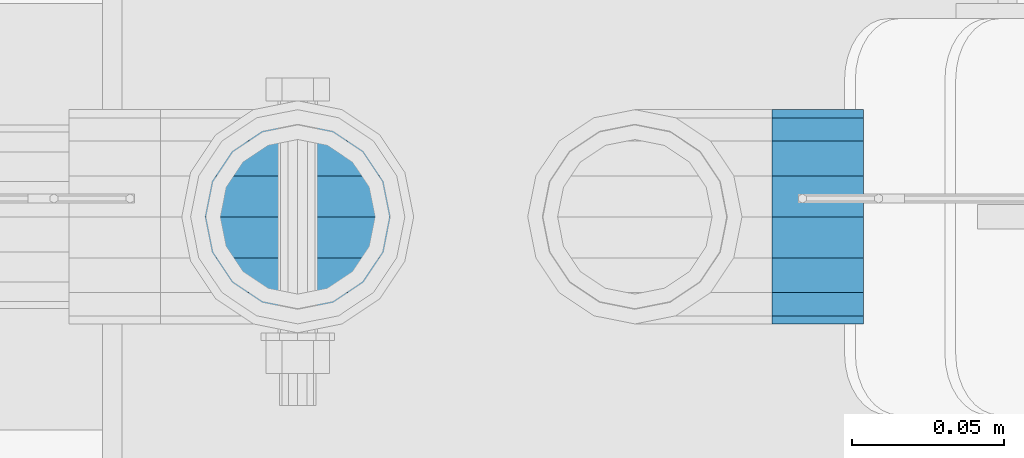
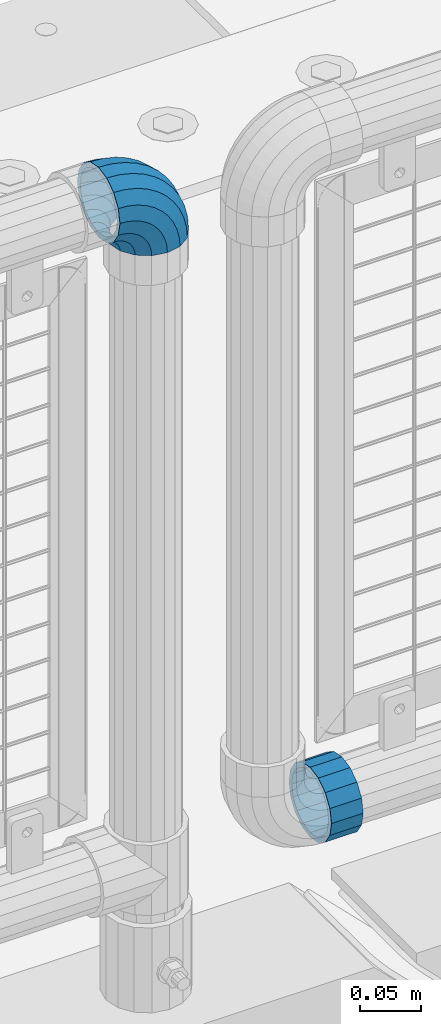
# One storey, part 182 of 270: 1 beam, 1 member.
"""IFC2X3 building model written with IfcOpenShell, lengths in millimetres."""

from ifc_helpers import new_model, si_unit, frame, origin_with_axes, place, context, subcontext, project, spatial, faceted_brep, material, type_object, element, save


model = new_model("IFC2X3")

# Units and contexts
model_context = context("Model", 3, precision=1e-05, world=origin_with_axes())
body_context = subcontext(model_context, "Body", "Model", "MODEL_VIEW")
ifc_project = project(units=[si_unit("LENGTHUNIT", "METRE", prefix="MILLI"), si_unit("AREAUNIT", "SQUARE_METRE"), si_unit("VOLUMEUNIT", "CUBIC_METRE"), si_unit("MASSUNIT", "GRAM", prefix="KILO"), si_unit("TIMEUNIT", "SECOND"), si_unit("PLANEANGLEUNIT", "RADIAN"), si_unit("SOLIDANGLEUNIT", "STERADIAN"), si_unit("THERMODYNAMICTEMPERATUREUNIT", "DEGREE_CELSIUS"), si_unit("LUMINOUSINTENSITYUNIT", "LUMEN")], contexts=[model_context])

# Site, building, storey
site_placement = place(None, origin_with_axes())
site = spatial("IfcSite", under=ifc_project, at=site_placement, CompositionType="ELEMENT")
building_placement = place(site_placement, origin_with_axes())
building = spatial("IfcBuilding", under=site, at=building_placement, Name="Standard", CompositionType="ELEMENT")
storey_placement = place(building_placement, origin_with_axes())
storey = spatial("IfcBuildingStorey", under=building, at=storey_placement, Name="Undefined", CompositionType="ELEMENT", Elevation=0.0)

# Beam
ifc_material = material(Name="Misc_Undefined")
beam_type = type_object("IfcBeamType", PredefinedType="NOTDEFINED")
beam_placement = place(storey_placement, frame((18739.61, -16335.5, 298.170000000001), z_axis=(0.0, 0.0, -1.0), x_axis=(1.0, 0.0, 0.0)))
element("IfcBeam", 1, at=beam_placement, inside=storey, type_object=beam_type, material=ifc_material, context=body_context, shape_type="Brep", body=[
    faceted_brep([(0.0, -30.3500000000004, 0.0), (0.0, -28.0397438117179, 11.614442172282), (30.0, -28.0397438117179, 11.6144421722805), (30.0, -30.3500000000004, 0.0), (0.0, -21.4606908090118, 21.46069080901), (30.0, -21.4606908090118, 21.4606908090117), (0.0, -11.6144421722802, 28.0397438117179), (30.0, -11.6144421722802, 28.0397438117176), (0.0, 0.0, 30.3499999999985), (30.0, 0.0, 30.35), (0.0, 11.6144421722802, 28.0397438117179), (30.0, 11.6144421722802, 28.0397438117176), (0.0, 21.4606908090118, 21.46069080901), (30.0, 21.4606908090118, 21.4606908090117), (0.0, 28.0397438117179, 11.614442172282), (30.0, 28.0397438117179, 11.6144421722805), (0.0, 30.3500000000004, 0.0), (30.0, 30.3500000000004, 0.0), (0.0, 28.0397438117179, -11.614442172282), (30.0, 28.0397438117179, -11.6144421722805), (0.0, 21.4606908090118, -21.46069080901), (30.0, 21.4606908090118, -21.4606908090117), (0.0, 11.6144421722802, -28.0397438117179), (30.0, 11.6144421722802, -28.0397438117176), (0.0, 0.0, -30.3499999999985), (30.0, 0.0, -30.35), (0.0, -11.6144421722802, -28.0397438117179), (30.0, -11.6144421722802, -28.0397438117176), (0.0, -21.4606908090118, -21.46069080901), (30.0, -21.4606908090118, -21.4606908090117), (0.0, -28.0397438117179, -11.614442172282), (30.0, -28.0397438117179, -11.6144421722805), (0.0, -35.1499999999996, 0.0), (0.0, -32.4743655677721, -13.4513226476338), (30.0, -32.4743655677721, -13.4513226476329), (30.0, -35.1499999999996, 0.0), (0.0, -24.8548033587067, -24.8548033587067), (30.0, -24.8548033587067, -24.8548033587072), (0.0, -13.4513226476338, -32.4743655677703), (30.0, -13.4513226476338, -32.4743655677718), (0.0, 0.0, -35.1499999999996), (30.0, 0.0, -35.15), (0.0, 13.4513226476338, -32.4743655677703), (30.0, 13.4513226476338, -32.4743655677718), (0.0, 24.8548033587067, -24.8548033587067), (30.0, 24.8548033587067, -24.8548033587072), (0.0, 32.4743655677721, -13.4513226476338), (30.0, 32.4743655677721, -13.4513226476329), (0.0, 35.1499999999996, 0.0), (30.0, 35.1499999999996, 0.0), (0.0, 32.4743655677721, 13.4513226476338), (30.0, 32.4743655677721, 13.4513226476329), (0.0, 24.8548033587067, 24.8548033587067), (30.0, 24.8548033587067, 24.8548033587072), (0.0, 13.4513226476338, 32.4743655677703), (30.0, 13.4513226476338, 32.4743655677718), (0.0, 0.0, 35.1499999999996), (30.0, 0.0, 35.15), (0.0, -13.4513226476338, 32.4743655677703), (30.0, -13.4513226476338, 32.4743655677718), (0.0, -24.8548033587067, 24.8548033587067), (30.0, -24.8548033587067, 24.8548033587072), (0.0, -32.4743655677721, 13.4513226476338), (30.0, -32.4743655677721, 13.4513226476329)], [[[0, 1, 2, 3]], [[1, 4, 5, 2]], [[4, 6, 7, 5]], [[6, 8, 9, 7]], [[8, 10, 11, 9]], [[10, 12, 13, 11]], [[12, 14, 15, 13]], [[14, 16, 17, 15]], [[16, 18, 19, 17]], [[18, 20, 21, 19]], [[20, 22, 23, 21]], [[22, 24, 25, 23]], [[24, 26, 27, 25]], [[26, 28, 29, 27]], [[28, 30, 31, 29]], [[30, 0, 3, 31]], [[32, 33, 34, 35]], [[33, 36, 37, 34]], [[36, 38, 39, 37]], [[38, 40, 41, 39]], [[40, 42, 43, 41]], [[42, 44, 45, 43]], [[44, 46, 47, 45]], [[46, 48, 49, 47]], [[48, 50, 51, 49]], [[50, 52, 53, 51]], [[52, 54, 55, 53]], [[54, 56, 57, 55]], [[56, 58, 59, 57]], [[58, 60, 61, 59]], [[60, 62, 63, 61]], [[62, 32, 35, 63]], [[37, 39, 41, 43, 45, 47, 49, 51, 53, 55, 57, 59, 61, 63, 35, 34], [5, 7, 9, 11, 13, 15, 17, 19, 21, 23, 25, 27, 29, 31, 3, 2]], [[62, 60, 58, 56, 54, 52, 50, 48, 46, 44, 42, 40, 38, 36, 33, 32], [30, 28, 26, 24, 22, 20, 18, 16, 14, 12, 10, 8, 6, 4, 1, 0]]]),
])

# Member
member_type = type_object("IfcMemberType", PredefinedType="NOTDEFINED")
member_placement = place(storey_placement, frame((18584.0, -16335.5, 924.85), z_axis=(0.707106781186547, 0.0, 0.707106781186548), x_axis=(-0.707106781186548, 0.0, 0.707106781186548)))
element("IfcMember", 2, at=member_placement, inside=storey, type_object=member_type, material=ifc_material, context=body_context, shape_type="Brep", body=[
    faceted_brep([(0.0, -35.1499999999996, 0.0), (9.51152146006916, -32.4743655677721, -9.51152146006947), (13.2759578763396, -32.4743655677721, -6.29638902527765), (5.36946880023311, -35.1499999999996, 4.58595959347795), (17.5749999999998, -24.8548033587067, -17.5750000000001), (19.9787556631106, -24.8548033587067, -15.5219987155636), (22.962844107702, -13.4513226476338, -22.9628441077024), (24.4574219585238, -13.4513226476338, -21.686354032394), (24.8548033587069, 0.0, -24.8548033587072), (26.0301204183136, 0.0, -23.8509877588015), (22.962844107702, 13.4513226476338, -22.9628441077024), (24.4574219585238, 13.4513226476338, -21.686354032394), (17.5749999999998, 24.8548033587067, -17.5750000000001), (19.9787556631106, 24.8548033587067, -15.5219987155636), (9.51152146006916, 32.4743655677721, -9.51152146006947), (13.2759578763396, 32.4743655677721, -6.29638902527765), (0.0, 35.1499999999996, 0.0), (5.36946880023311, 35.1499999999996, 4.58595959347795), (-9.51152146006962, 32.4743655677721, 9.5115214600693), (-2.53702027587315, 32.4743655677721, 15.4683082122336), (-17.5750000000003, 24.8548033587067, 17.5749999999999), (-9.23981806264419, 24.8548033587067, 24.6939179025195), (-22.9628441077025, 13.4513226476338, 22.9628441077022), (-13.7184843580576, 13.4513226476338, 30.8582732193499), (-24.8548033587074, 0.0, 24.8548033587071), (-15.2911828178471, 0.0, 33.0229069457573), (-22.9628441077025, -13.4513226476338, 22.9628441077022), (-13.7184843580576, -13.4513226476338, 30.8582732193499), (-17.5750000000003, -24.8548033587067, 17.5749999999999), (-9.23981806264419, -24.8548033587067, 24.6939179025195), (-9.51152146006962, -32.4743655677721, 9.5115214600693), (-2.53702027587315, -32.4743655677721, 15.4683082122336), (0.0, -30.3500000000004, 0.0), (-8.21265081971887, -28.0397438117179, 8.2126508197185), (-1.45732902223699, -28.0397438117179, 13.982240691038), (5.36946880023311, -30.3500000000004, 4.58595959347795), (-15.1750000000002, -21.4606908090118, 15.1749999999999), (-7.24480876131247, -21.4606908090118, 21.9480231689948), (-19.8270929919993, -11.6144421722802, 19.827092991999), (-11.1118790903536, -11.6144421722802, 27.2705888550771), (-21.4606908090118, 0.0, 21.4606908090117), (-12.4698136068432, 0.0, 29.1396253727576), (-19.8270929919993, 11.6144421722802, 19.827092991999), (-11.1118790903536, 11.6144421722802, 27.2705888550771), (-15.1750000000002, 21.4606908090118, 15.1749999999999), (-7.24480876131247, 21.4606908090118, 21.9480231689948), (-8.21265081971887, 28.0397438117179, 8.2126508197185), (-1.45732902223699, 28.0397438117179, 13.982240691038), (0.0, 30.3500000000004, 0.0), (5.36946880023311, 30.3500000000004, 4.58595959347795), (8.21265081971842, 28.0397438117179, -8.21265081971868), (12.1962666227034, 28.0397438117179, -4.81032150408211), (15.1749999999997, 21.4606908090118, -15.175), (17.9837463617789, 21.4606908090118, -12.7761039820388), (19.8270929919988, 11.6144421722802, -19.8270929919991), (21.85081669082, 11.6144421722802, -18.0986696681213), (21.4606908090116, 0.0, -21.4606908090118), (23.2087512073099, 0.0, -19.9677061858016), (19.8270929919988, -11.6144421722802, -19.8270929919991), (21.85081669082, -11.6144421722802, -18.0986696681213), (15.1749999999997, -21.4606908090118, -15.175), (17.9837463617789, -21.4606908090118, -12.7761039820388), (8.21265081971842, -28.0397438117179, -8.21265081971868), (12.1962666227034, -28.0397438117179, -4.81032150408211), (17.4970053560717, -32.4743655677721, -3.70972780292183), (11.390232665115, -35.1499999999996, 8.27548843508188), (22.6740772628625, -24.8548033587067, -13.8703035149452), (26.1332861179524, -13.4513226476338, -20.6593831546809), (27.3479987309599, 0.0, -23.0433908901392), (26.1332861179524, 13.4513226476338, -20.6593831546809), (22.6740772628625, 24.8548033587067, -13.8703035149451), (17.4970053560717, 32.4743655677721, -3.70972780292183), (11.390232665115, 35.1499999999996, 8.27548843508188), (5.28345997415818, 32.4743655677721, 20.2607046730856), (0.106388067367334, 24.8548033587067, 30.4212803851089), (-3.35282078772252, 13.4513226476338, 37.2103600248446), (-4.5675334007301, 0.0, 39.594367760303), (-3.35282078772252, -13.4513226476338, 37.2103600248446), (0.106388067367334, -24.8548033587067, 30.4212803851089), (5.28345997415818, -32.4743655677721, 20.2607046730856), (6.11738625912517, -28.0397438117179, 18.6240321853922), (11.390232665115, -30.3500000000004, 8.27548843508188), (1.64728291997562, -21.4606908090118, 27.3971039595006), (-1.33954464053568, -11.6144421722802, 33.2590831078927), (-2.38837900198041, 0.0, 35.3175364441988), (-1.33954464053568, 11.6144421722802, 33.2590831078927), (1.64728291997562, 21.4606908090118, 27.3971039595006), (6.11738625912517, 28.0397438117179, 18.6240321853922), (11.390232665115, 30.3500000000004, 8.27548843508188), (16.6630790711047, 28.0397438117179, -2.07305531522857), (21.133182410254, 21.4606908090118, -10.8461270893369), (24.1200099707653, 11.6144421722802, -16.7081062377289), (25.16884433221, 0.0, -18.7665595740351), (24.1200099707653, -11.6144421722802, -16.7081062377289), (21.133182410254, -21.4606908090118, -10.8461270893369), (16.6630790711047, -28.0397438117179, -2.07305531522857), (22.070727701461, -32.4743655677721, -1.81522997693261), (17.9140404065217, -35.1499999999996, 10.9777380798872), (25.59459703621, -24.8548033587067, -12.6605846156459), (27.9491712485078, -13.4513226476338, -19.907218905893), (28.7759877588012, 0.0, -22.4518984678874), (27.9491712485078, 13.4513226476338, -19.907218905893), (25.59459703621, 24.8548033587067, -12.6605846156459), (22.070727701461, 32.4743655677721, -1.81522997693261), (17.9140404065217, 35.1499999999996, 10.9777380798872), (13.7573531115827, 32.4743655677721, 23.770706136707), (10.2334837768337, 24.8548033587067, 34.6160607754204), (7.87890956453566, 13.4513226476338, 41.8626950656675), (7.0520930542425, 0.0, 44.4073746276618), (7.87890956453566, -13.4513226476338, 41.8626950656675), (10.2334837768337, -24.8548033587067, 34.6160607754204), (13.7573531115827, -32.4743655677721, 23.770706136707), (14.3249803951021, -28.0397438117179, 22.0237289909678), (17.9140404065217, -30.3500000000004, 10.9777380798872), (11.2823222355109, -21.4606908090118, 31.3880679179933), (9.24928305078129, -11.6144421722802, 37.6451191472678), (8.53537462724216, 0.0, 39.8423033494451), (9.24928305078129, 11.6144421722802, 37.6451191472678), (11.2823222355109, 21.4606908090118, 31.3880679179933), (14.3249803951021, 28.0397438117179, 22.0237289909677), (17.9140404065217, 30.3500000000004, 10.9777380798872), (21.5031004179416, 28.0397438117179, -0.068252831193405), (24.5457585775328, 21.4606908090118, -9.43259175821888), (26.5787977622624, 11.6144421722802, -15.6896429874934), (27.2927061858015, 0.0, -17.8868271896707), (26.5787977622624, -11.6144421722802, -15.6896429874934), (24.5457585775328, -21.4606908090118, -9.43259175821888), (21.5031004179416, -28.0397438117179, -0.068252831193405), (26.8845046890501, -32.4743655677721, -0.65954437126382), (24.7802542265842, -35.1499999999996, 12.6261701733866), (28.6684020936837, -24.8548033587067, -11.9226293117934), (29.8603642316994, -13.4513226476338, -19.4483820661258), (30.2789256727483, 0.0, -22.0910749985325), (29.8603642316994, 13.4513226476338, -19.4483820661258), (28.6684020936837, 24.8548033587067, -11.9226293117934), (26.8845046890501, 32.4743655677721, -0.65954437126382), (24.7802542265842, 35.1499999999996, 12.6261701733866), (22.6760037641182, 32.4743655677721, 25.9118847180369), (20.8921063594846, 24.8548033587067, 37.1749696585664), (19.7001442214689, 13.4513226476338, 44.7007224128988), (19.28158278042, 0.0, 47.3434153453055), (19.7001442214689, -13.4513226476338, 44.7007224128988), (20.8921063594846, -24.8548033587067, 37.1749696585664), (22.6760037641182, -32.4743655677721, 25.9118847180369), (22.9633551786228, -28.0397438117179, 24.0976192894644), (24.7802542265842, -30.3500000000004, 12.6261701733866), (21.4230625404825, -21.4606908090118, 33.8226442665647), (20.393871903533, -11.6144421722802, 40.3206982094946), (20.0324682126131, 0.0, 42.602511310449), (20.393871903533, 11.6144421722802, 40.3206982094946), (21.4230625404825, 21.4606908090118, 33.8226442665647), (22.9633551786228, 28.0397438117179, 24.0976192894644), (24.7802542265842, 30.3500000000004, 12.6261701733866), (26.5971532745455, 28.0397438117179, 1.15472105730865), (28.1374459126855, 21.4606908090118, -8.57030391979166), (29.1666365496353, 11.6144421722802, -15.0683578627215), (29.5280402405551, 0.0, -17.3501709636759), (29.1666365496353, -11.6144421722802, -15.0683578627215), (28.1374459126855, -21.4606908090118, -8.57030391979166), (26.5971532745455, -28.0397438117179, 1.15472105730865), (31.8198051533946, -32.4743655677721, -0.271127801027632), (31.8198051533946, -35.1499999999996, 13.1801948466053), (31.8198051533946, -24.8548033587067, -11.6746085121019), (31.8198051533946, -13.4513226476338, -19.2941707211664), (31.8198051533946, 0.0, -21.9698051533946), (31.8198051533946, 13.4513226476338, -19.2941707211664), (31.8198051533946, 24.8548033587067, -11.6746085121019), (31.8198051533946, 32.4743655677721, -0.271127801027575), (31.8198051533946, 35.1499999999996, 13.1801948466053), (31.8198051533946, 32.4743655677721, 26.6315174942382), (31.8198051533946, 24.8548033587067, 38.0349982053124), (31.8198051533946, 13.4513226476338, 45.654560414377), (31.8198051533946, 0.0, 48.3301948466053), (31.8198051533946, -13.4513226476338, 45.654560414377), (31.8198051533946, -24.8548033587067, 38.0349982053124), (31.8198051533946, -32.4743655677721, 26.6315174942382), (31.8198051533946, -28.0397438117179, 24.7946370188858), (31.8198051533946, -30.3500000000004, 13.1801948466053), (31.8198051533946, -21.4606908090118, 34.640885655617), (31.8198051533946, -11.6144421722802, 41.2199386583228), (31.8198051533946, 0.0, 43.5301948466053), (31.8198051533946, 11.6144421722802, 41.2199386583228), (31.8198051533946, 21.4606908090118, 34.640885655617), (31.8198051533946, 28.0397438117179, 24.7946370188858), (31.8198051533946, 30.3500000000004, 13.1801948466053), (31.8198051533946, 28.0397438117179, 1.56575267432484), (31.8198051533946, 21.4606908090118, -8.28049596240649), (31.8198051533946, 11.6144421722802, -14.8595489651122), (31.8198051533946, 0.0, -17.1698051533947), (31.8198051533946, -11.6144421722802, -14.8595489651122), (31.8198051533946, -21.4606908090118, -8.28049596240649), (31.8198051533946, -28.0397438117179, 1.56575267432484), (36.7551056177388, -32.4743655677721, -0.659544371263877), (38.8593560802049, -35.1499999999996, 12.6261701733865), (34.9712082131055, -24.8548033587067, -11.9226293117935), (33.7792460750895, -13.4513226476338, -19.4483820661258), (33.3606846340408, 0.0, -22.0910749985325), (33.7792460750895, 13.4513226476338, -19.4483820661258), (34.9712082131055, 24.8548033587067, -11.9226293117935), (36.7551056177388, 32.4743655677721, -0.659544371263877), (38.8593560802049, 35.1499999999996, 12.6261701733865), (40.9636065426707, 32.4743655677721, 25.9118847180369), (42.7475039473045, 24.8548033587067, 37.1749696585664), (43.9394660853202, 13.4513226476338, 44.7007224128988), (44.3580275263691, 0.0, 47.3434153453057), (43.9394660853202, -13.4513226476338, 44.7007224128988), (42.7475039473045, -24.8548033587067, 37.1749696585664), (40.9636065426707, -32.4743655677721, 25.9118847180369), (40.6762551281663, -28.0397438117179, 24.0976192894645), (38.8593560802049, -30.3500000000004, 12.6261701733865), (42.2165477663066, -21.4606908090118, 33.8226442665647), (43.2457384032562, -11.6144421722802, 40.3206982094946), (43.6071420941757, 0.0, 42.6025113104489), (43.2457384032562, 11.6144421722802, 40.3206982094946), (42.2165477663066, 21.4606908090118, 33.8226442665647), (40.6762551281663, 28.0397438117179, 24.0976192894645), (38.8593560802049, 30.3500000000004, 12.6261701733865), (37.0424570322434, 28.0397438117179, 1.15472105730865), (35.5021643941034, 21.4606908090118, -8.5703039197916), (34.4729737571538, 11.6144421722802, -15.0683578627216), (34.111570066234, 0.0, -17.3501709636759), (34.4729737571538, -11.6144421722802, -15.0683578627216), (35.5021643941034, -21.4606908090118, -8.5703039197916), (37.0424570322434, -28.0397438117179, 1.15472105730865), (41.5688826053279, -32.4743655677721, -1.81522997693256), (45.7255699002671, -35.1499999999996, 10.9777380798873), (38.0450132705791, -24.8548033587067, -12.6605846156459), (35.6904390582811, -13.4513226476338, -19.907218905893), (34.8636225479877, 0.0, -22.4518984678874), (35.6904390582811, 13.4513226476338, -19.907218905893), (38.0450132705791, 24.8548033587067, -12.6605846156459), (41.5688826053279, 32.4743655677721, -1.81522997693256), (45.7255699002671, 35.1499999999996, 10.9777380798873), (49.8822571952064, 32.4743655677721, 23.7707061367072), (53.4061265299551, 24.8548033587067, 34.6160607754204), (55.7607007422532, 13.4513226476338, 41.8626950656676), (56.5875172525466, 0.0, 44.4073746276619), (55.7607007422532, -13.4513226476338, 41.8626950656676), (53.4061265299551, -24.8548033587067, 34.6160607754204), (49.8822571952064, -32.4743655677721, 23.7707061367072), (49.314629911687, -28.0397438117179, 22.0237289909678), (45.7255699002671, -30.3500000000004, 10.9777380798873), (52.3572880712779, -21.4606908090118, 31.3880679179933), (54.3903272560076, -11.6144421722802, 37.6451191472679), (55.1042356795469, 0.0, 39.8423033494451), (54.3903272560076, 11.6144421722802, 37.6451191472679), (52.3572880712779, 21.4606908090118, 31.3880679179933), (49.3146299116868, 28.0397438117179, 22.0237289909677), (45.7255699002671, 30.3500000000004, 10.9777380798873), (42.1365098888475, 28.0397438117179, -0.0682528311933481), (39.0938517292564, 21.4606908090118, -9.43259175821888), (37.0608125445267, 11.6144421722802, -15.6896429874935), (36.3469041209873, 0.0, -17.8868271896708), (37.0608125445267, -11.6144421722802, -15.6896429874935), (39.0938517292564, -21.4606908090118, -9.43259175821888), (42.1365098888475, -28.0397438117179, -0.0682528311933481), (46.1426049507174, -32.4743655677721, -3.70972780292183), (52.2493776416741, -35.1499999999996, 8.27548843508177), (40.9655330439266, -24.8548033587067, -13.8703035149451), (37.5063241888367, -13.4513226476338, -20.6593831546809), (36.2916115758289, 0.0, -23.0433908901393), (37.5063241888367, 13.4513226476338, -20.6593831546809), (40.9655330439266, 24.8548033587067, -13.8703035149451), (46.1426049507174, 32.4743655677721, -3.70972780292183), (52.2493776416741, 35.1499999999996, 8.27548843508177), (58.3561503326309, 32.4743655677721, 20.2607046730855), (63.5332222394218, 24.8548033587067, 30.421280385109), (66.9924310945114, 13.4513226476338, 37.2103600248446), (68.2071437075192, 0.0, 39.594367760303), (66.9924310945114, -13.4513226476338, 37.2103600248446), (63.5332222394218, -24.8548033587067, 30.421280385109), (58.3561503326309, -32.4743655677721, 20.2607046730855), (57.5222240476637, -28.0397438117179, 18.6240321853922), (52.2493776416741, -30.3500000000004, 8.27548843508177), (61.9923273868133, -21.4606908090118, 27.3971039595006), (64.9791549473246, -11.6144421722802, 33.2590831078926), (66.0279893087693, 0.0, 35.3175364441988), (64.9791549473246, 11.6144421722802, 33.2590831078926), (61.9923273868133, 21.4606908090118, 27.3971039595006), (57.5222240476637, 28.0397438117179, 18.6240321853922), (52.2493776416741, 30.3500000000004, 8.27548843508177), (46.9765312356844, 28.0397438117179, -2.07305531522863), (42.5064278965349, 21.4606908090118, -10.846127089337), (39.5196003360236, 11.6144421722802, -16.708106237729), (38.4707659745789, 0.0, -18.766559574035), (39.5196003360236, -11.6144421722802, -16.708106237729), (42.5064278965349, -21.4606908090118, -10.846127089337), (46.9765312356844, -28.0397438117179, -2.07305531522863), (50.3636524304493, -32.4743655677721, -6.29638902527759), (58.2701415065558, -35.1499999999996, 4.58595959347801), (43.6608546436782, -24.8548033587067, -15.5219987155636), (39.1821883482653, -13.4513226476338, -21.686354032394), (37.6094898884753, 0.0, -23.8509877588015), (39.1821883482653, 13.4513226476338, -21.686354032394), (43.6608546436782, 24.8548033587067, -15.5219987155636), (50.3636524304493, 32.4743655677721, -6.29638902527759), (58.2701415065558, 35.1499999999996, 4.58595959347801), (66.1766305826623, 32.4743655677721, 15.4683082122336), (72.8794283694331, 24.8548033587067, 24.6939179025195), (77.3580946648465, 13.4513226476338, 30.8582732193499), (78.9307931246362, 0.0, 33.0229069457573), (77.3580946648465, -13.4513226476338, 30.8582732193499), (72.8794283694331, -24.8548033587067, 24.6939179025195), (66.1766305826623, -32.4743655677721, 15.4683082122336), (65.0969393290261, -28.0397438117179, 13.982240691038), (58.2701415065558, -30.3500000000004, 4.58595959347801), (70.8844190681016, -21.4606908090118, 21.9480231689947), (74.7514893971425, -11.6144421722802, 27.2705888550772), (76.1094239136323, 0.0, 29.1396253727577), (74.7514893971425, 11.6144421722802, 27.2705888550772), (70.8844190681016, 21.4606908090118, 21.9480231689947), (65.0969393290261, 28.0397438117179, 13.982240691038), (58.2701415065558, 30.3500000000004, 4.58595959347801), (51.4433436840854, 28.0397438117179, -4.81032150408205), (45.65586394501, 21.4606908090118, -12.7761039820388), (41.7887936159691, 11.6144421722802, -18.0986696681213), (40.4308590994792, 0.0, -19.9677061858017), (41.7887936159691, -11.6144421722802, -18.0986696681213), (45.65586394501, -21.4606908090118, -12.7761039820388), (51.4433436840854, -28.0397438117179, -4.81032150408205), (54.1280888467197, -32.4743655677721, -9.51152146006942), (63.6396103067891, -35.1499999999996, -2.8421709430404e-14), (46.0646103067891, -24.8548033587067, -17.5750000000001), (40.6767661990866, -13.4513226476338, -22.9628441077024), (38.784806948082, 0.0, -24.8548033587072), (40.6767661990866, 13.4513226476338, -22.9628441077024), (46.0646103067891, 24.8548033587067, -17.5750000000001), (54.1280888467197, 32.4743655677721, -9.51152146006942), (63.6396103067891, 35.1499999999996, -2.8421709430404e-14), (73.1511317668585, 32.4743655677721, 9.51152146006936), (81.2146103067892, 24.8548033587067, 17.575), (86.6024544144916, 13.4513226476338, 22.9628441077024), (88.4944136654963, 0.0, 24.8548033587071), (86.6024544144916, -13.4513226476338, 22.9628441077024), (81.2146103067892, -24.8548033587067, 17.575), (73.1511317668585, -32.4743655677721, 9.51152146006936), (71.8522611265075, -28.0397438117179, 8.2126508197185), (63.6396103067891, -30.3500000000004, -2.8421709430404e-14), (78.8146103067891, -21.4606908090118, 15.1749999999999), (83.4667032987882, -11.6144421722802, 19.827092991999), (85.1003011158009, 0.0, 21.4606908090117), (83.4667032987882, 11.6144421722802, 19.827092991999), (78.8146103067891, 21.4606908090118, 15.1749999999999), (71.8522611265075, 28.0397438117179, 8.2126508197185), (63.6396103067891, 30.3500000000004, -2.8421709430404e-14), (55.4269594870707, 28.0397438117179, -8.21265081971856), (48.4646103067892, 21.4606908090118, -15.175), (43.8125173147901, 11.6144421722802, -19.8270929919991), (42.1789194977773, 0.0, -21.4606908090117), (43.8125173147901, -11.6144421722802, -19.8270929919991), (48.4646103067892, -21.4606908090118, -15.175), (55.4269594870707, -28.0397438117179, -8.21265081971856)], [[[0, 1, 2, 3]], [[1, 4, 5, 2]], [[4, 6, 7, 5]], [[6, 8, 9, 7]], [[8, 10, 11, 9]], [[10, 12, 13, 11]], [[12, 14, 15, 13]], [[14, 16, 17, 15]], [[16, 18, 19, 17]], [[18, 20, 21, 19]], [[20, 22, 23, 21]], [[22, 24, 25, 23]], [[24, 26, 27, 25]], [[26, 28, 29, 27]], [[28, 30, 31, 29]], [[30, 0, 3, 31]], [[32, 33, 34, 35]], [[33, 36, 37, 34]], [[36, 38, 39, 37]], [[38, 40, 41, 39]], [[40, 42, 43, 41]], [[42, 44, 45, 43]], [[44, 46, 47, 45]], [[46, 48, 49, 47]], [[48, 50, 51, 49]], [[50, 52, 53, 51]], [[52, 54, 55, 53]], [[54, 56, 57, 55]], [[56, 58, 59, 57]], [[58, 60, 61, 59]], [[60, 62, 63, 61]], [[62, 32, 35, 63]], [[30, 28, 26, 24, 22, 20, 18, 16, 14, 12, 10, 8, 6, 4, 1, 0], [62, 60, 58, 56, 54, 52, 50, 48, 46, 44, 42, 40, 38, 36, 33, 32]], [[3, 2, 64, 65]], [[2, 5, 66, 64]], [[5, 7, 67, 66]], [[7, 9, 68, 67]], [[9, 11, 69, 68]], [[11, 13, 70, 69]], [[13, 15, 71, 70]], [[15, 17, 72, 71]], [[17, 19, 73, 72]], [[19, 21, 74, 73]], [[21, 23, 75, 74]], [[23, 25, 76, 75]], [[25, 27, 77, 76]], [[27, 29, 78, 77]], [[29, 31, 79, 78]], [[31, 3, 65, 79]], [[35, 34, 80, 81]], [[34, 37, 82, 80]], [[37, 39, 83, 82]], [[39, 41, 84, 83]], [[41, 43, 85, 84]], [[43, 45, 86, 85]], [[45, 47, 87, 86]], [[47, 49, 88, 87]], [[49, 51, 89, 88]], [[51, 53, 90, 89]], [[53, 55, 91, 90]], [[55, 57, 92, 91]], [[57, 59, 93, 92]], [[59, 61, 94, 93]], [[61, 63, 95, 94]], [[63, 35, 81, 95]], [[65, 64, 96, 97]], [[64, 66, 98, 96]], [[66, 67, 99, 98]], [[67, 68, 100, 99]], [[68, 69, 101, 100]], [[69, 70, 102, 101]], [[70, 71, 103, 102]], [[71, 72, 104, 103]], [[72, 73, 105, 104]], [[73, 74, 106, 105]], [[74, 75, 107, 106]], [[75, 76, 108, 107]], [[76, 77, 109, 108]], [[77, 78, 110, 109]], [[78, 79, 111, 110]], [[79, 65, 97, 111]], [[81, 80, 112, 113]], [[80, 82, 114, 112]], [[82, 83, 115, 114]], [[83, 84, 116, 115]], [[84, 85, 117, 116]], [[85, 86, 118, 117]], [[86, 87, 119, 118]], [[87, 88, 120, 119]], [[88, 89, 121, 120]], [[89, 90, 122, 121]], [[90, 91, 123, 122]], [[91, 92, 124, 123]], [[92, 93, 125, 124]], [[93, 94, 126, 125]], [[94, 95, 127, 126]], [[95, 81, 113, 127]], [[97, 96, 128, 129]], [[96, 98, 130, 128]], [[98, 99, 131, 130]], [[99, 100, 132, 131]], [[100, 101, 133, 132]], [[101, 102, 134, 133]], [[102, 103, 135, 134]], [[103, 104, 136, 135]], [[104, 105, 137, 136]], [[105, 106, 138, 137]], [[106, 107, 139, 138]], [[107, 108, 140, 139]], [[108, 109, 141, 140]], [[109, 110, 142, 141]], [[110, 111, 143, 142]], [[111, 97, 129, 143]], [[113, 112, 144, 145]], [[112, 114, 146, 144]], [[114, 115, 147, 146]], [[115, 116, 148, 147]], [[116, 117, 149, 148]], [[117, 118, 150, 149]], [[118, 119, 151, 150]], [[119, 120, 152, 151]], [[120, 121, 153, 152]], [[121, 122, 154, 153]], [[122, 123, 155, 154]], [[123, 124, 156, 155]], [[124, 125, 157, 156]], [[125, 126, 158, 157]], [[126, 127, 159, 158]], [[127, 113, 145, 159]], [[129, 128, 160, 161]], [[128, 130, 162, 160]], [[130, 131, 163, 162]], [[131, 132, 164, 163]], [[132, 133, 165, 164]], [[133, 134, 166, 165]], [[134, 135, 167, 166]], [[135, 136, 168, 167]], [[136, 137, 169, 168]], [[137, 138, 170, 169]], [[138, 139, 171, 170]], [[139, 140, 172, 171]], [[140, 141, 173, 172]], [[141, 142, 174, 173]], [[142, 143, 175, 174]], [[143, 129, 161, 175]], [[145, 144, 176, 177]], [[144, 146, 178, 176]], [[146, 147, 179, 178]], [[147, 148, 180, 179]], [[148, 149, 181, 180]], [[149, 150, 182, 181]], [[150, 151, 183, 182]], [[151, 152, 184, 183]], [[152, 153, 185, 184]], [[153, 154, 186, 185]], [[154, 155, 187, 186]], [[155, 156, 188, 187]], [[156, 157, 189, 188]], [[157, 158, 190, 189]], [[158, 159, 191, 190]], [[159, 145, 177, 191]], [[161, 160, 192, 193]], [[160, 162, 194, 192]], [[162, 163, 195, 194]], [[163, 164, 196, 195]], [[164, 165, 197, 196]], [[165, 166, 198, 197]], [[166, 167, 199, 198]], [[167, 168, 200, 199]], [[168, 169, 201, 200]], [[169, 170, 202, 201]], [[170, 171, 203, 202]], [[171, 172, 204, 203]], [[172, 173, 205, 204]], [[173, 174, 206, 205]], [[174, 175, 207, 206]], [[175, 161, 193, 207]], [[177, 176, 208, 209]], [[176, 178, 210, 208]], [[178, 179, 211, 210]], [[179, 180, 212, 211]], [[180, 181, 213, 212]], [[181, 182, 214, 213]], [[182, 183, 215, 214]], [[183, 184, 216, 215]], [[184, 185, 217, 216]], [[185, 186, 218, 217]], [[186, 187, 219, 218]], [[187, 188, 220, 219]], [[188, 189, 221, 220]], [[189, 190, 222, 221]], [[190, 191, 223, 222]], [[191, 177, 209, 223]], [[193, 192, 224, 225]], [[192, 194, 226, 224]], [[194, 195, 227, 226]], [[195, 196, 228, 227]], [[196, 197, 229, 228]], [[197, 198, 230, 229]], [[198, 199, 231, 230]], [[199, 200, 232, 231]], [[200, 201, 233, 232]], [[201, 202, 234, 233]], [[202, 203, 235, 234]], [[203, 204, 236, 235]], [[204, 205, 237, 236]], [[205, 206, 238, 237]], [[206, 207, 239, 238]], [[207, 193, 225, 239]], [[209, 208, 240, 241]], [[208, 210, 242, 240]], [[210, 211, 243, 242]], [[211, 212, 244, 243]], [[212, 213, 245, 244]], [[213, 214, 246, 245]], [[214, 215, 247, 246]], [[215, 216, 248, 247]], [[216, 217, 249, 248]], [[217, 218, 250, 249]], [[218, 219, 251, 250]], [[219, 220, 252, 251]], [[220, 221, 253, 252]], [[221, 222, 254, 253]], [[222, 223, 255, 254]], [[223, 209, 241, 255]], [[225, 224, 256, 257]], [[224, 226, 258, 256]], [[226, 227, 259, 258]], [[227, 228, 260, 259]], [[228, 229, 261, 260]], [[229, 230, 262, 261]], [[230, 231, 263, 262]], [[231, 232, 264, 263]], [[232, 233, 265, 264]], [[233, 234, 266, 265]], [[234, 235, 267, 266]], [[235, 236, 268, 267]], [[236, 237, 269, 268]], [[237, 238, 270, 269]], [[238, 239, 271, 270]], [[239, 225, 257, 271]], [[241, 240, 272, 273]], [[240, 242, 274, 272]], [[242, 243, 275, 274]], [[243, 244, 276, 275]], [[244, 245, 277, 276]], [[245, 246, 278, 277]], [[246, 247, 279, 278]], [[247, 248, 280, 279]], [[248, 249, 281, 280]], [[249, 250, 282, 281]], [[250, 251, 283, 282]], [[251, 252, 284, 283]], [[252, 253, 285, 284]], [[253, 254, 286, 285]], [[254, 255, 287, 286]], [[255, 241, 273, 287]], [[257, 256, 288, 289]], [[256, 258, 290, 288]], [[258, 259, 291, 290]], [[259, 260, 292, 291]], [[260, 261, 293, 292]], [[261, 262, 294, 293]], [[262, 263, 295, 294]], [[263, 264, 296, 295]], [[264, 265, 297, 296]], [[265, 266, 298, 297]], [[266, 267, 299, 298]], [[267, 268, 300, 299]], [[268, 269, 301, 300]], [[269, 270, 302, 301]], [[270, 271, 303, 302]], [[271, 257, 289, 303]], [[273, 272, 304, 305]], [[272, 274, 306, 304]], [[274, 275, 307, 306]], [[275, 276, 308, 307]], [[276, 277, 309, 308]], [[277, 278, 310, 309]], [[278, 279, 311, 310]], [[279, 280, 312, 311]], [[280, 281, 313, 312]], [[281, 282, 314, 313]], [[282, 283, 315, 314]], [[283, 284, 316, 315]], [[284, 285, 317, 316]], [[285, 286, 318, 317]], [[286, 287, 319, 318]], [[287, 273, 305, 319]], [[289, 288, 320, 321]], [[288, 290, 322, 320]], [[290, 291, 323, 322]], [[291, 292, 324, 323]], [[292, 293, 325, 324]], [[293, 294, 326, 325]], [[294, 295, 327, 326]], [[295, 296, 328, 327]], [[296, 297, 329, 328]], [[297, 298, 330, 329]], [[298, 299, 331, 330]], [[299, 300, 332, 331]], [[300, 301, 333, 332]], [[301, 302, 334, 333]], [[302, 303, 335, 334]], [[303, 289, 321, 335]], [[305, 304, 336, 337]], [[304, 306, 338, 336]], [[306, 307, 339, 338]], [[307, 308, 340, 339]], [[308, 309, 341, 340]], [[309, 310, 342, 341]], [[310, 311, 343, 342]], [[311, 312, 344, 343]], [[312, 313, 345, 344]], [[313, 314, 346, 345]], [[314, 315, 347, 346]], [[315, 316, 348, 347]], [[316, 317, 349, 348]], [[317, 318, 350, 349]], [[318, 319, 351, 350]], [[319, 305, 337, 351]], [[322, 323, 324, 325, 326, 327, 328, 329, 330, 331, 332, 333, 334, 335, 321, 320], [338, 339, 340, 341, 342, 343, 344, 345, 346, 347, 348, 349, 350, 351, 337, 336]]]),
])

save(model, "model.ifc")
